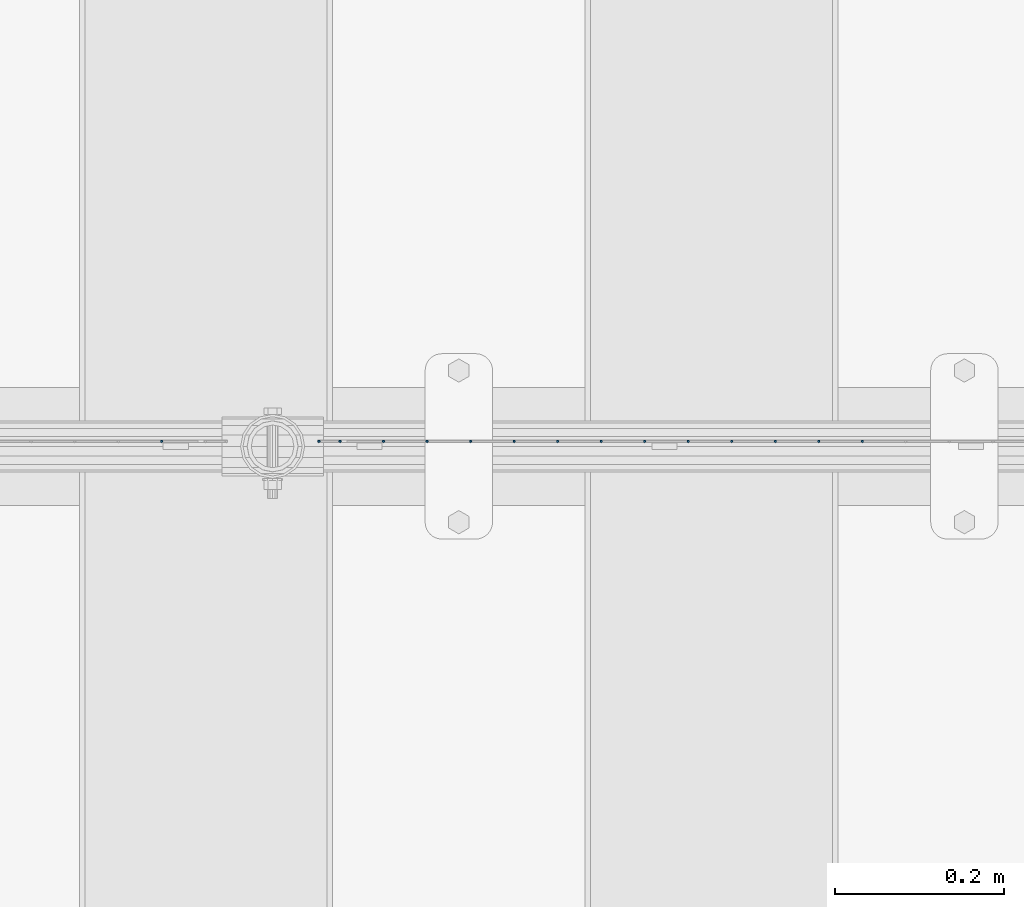
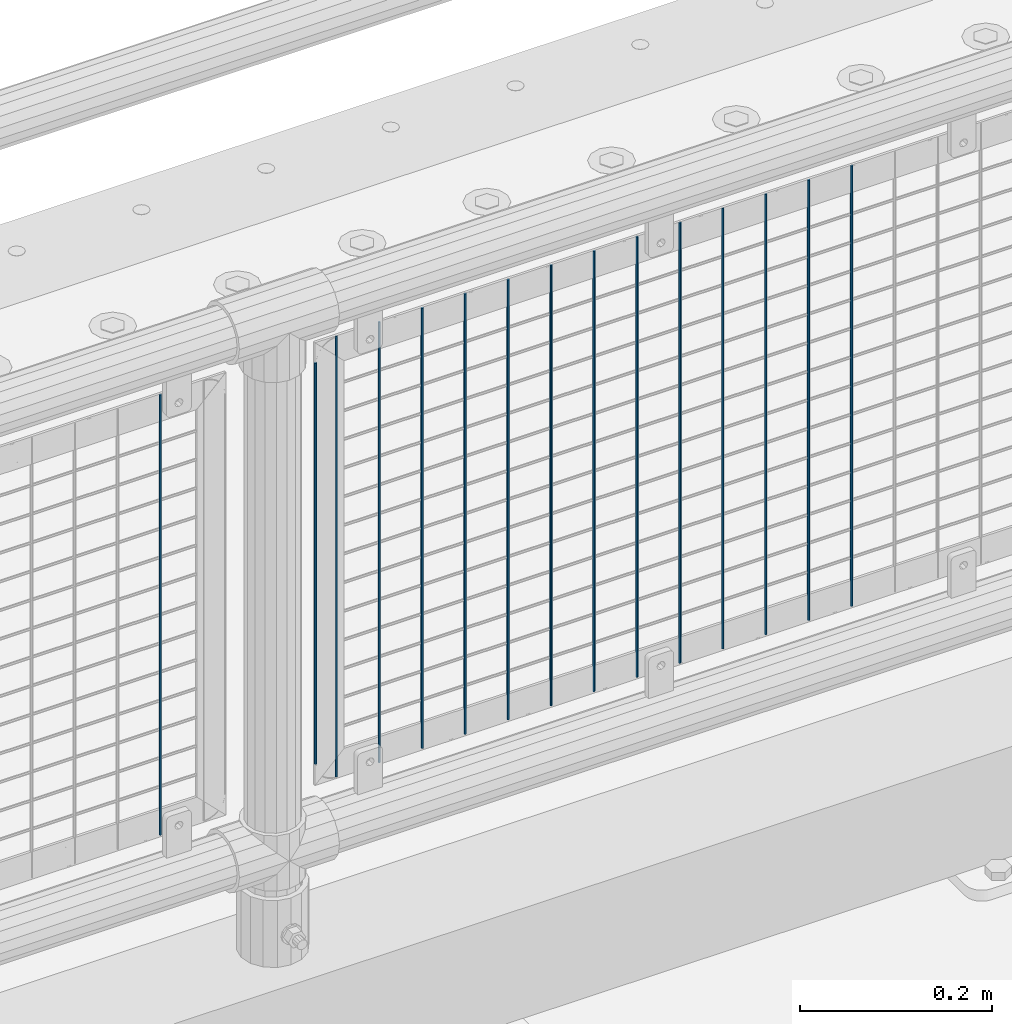
# One storey, part 56 of 193: 15 columns.
"""IFC2X3 building model written with IfcOpenShell, lengths in millimetres."""

from ifc_helpers import new_model, si_unit, frame, origin_with_axes, place, context, subcontext, project, spatial, faceted_brep, material, type_object, element, save


model = new_model("IFC2X3")

# Units and contexts
model_context = context("Model", 3, precision=1e-05, world=origin_with_axes())
body_context = subcontext(model_context, "Body", "Model", "MODEL_VIEW")
ifc_project = project(units=[si_unit("LENGTHUNIT", "METRE", prefix="MILLI"), si_unit("AREAUNIT", "SQUARE_METRE"), si_unit("VOLUMEUNIT", "CUBIC_METRE"), si_unit("MASSUNIT", "GRAM", prefix="KILO"), si_unit("TIMEUNIT", "SECOND"), si_unit("PLANEANGLEUNIT", "RADIAN"), si_unit("SOLIDANGLEUNIT", "STERADIAN"), si_unit("THERMODYNAMICTEMPERATUREUNIT", "DEGREE_CELSIUS"), si_unit("LUMINOUSINTENSITYUNIT", "LUMEN")], contexts=[model_context])

# Site, building, storey
site_placement = place(None, origin_with_axes())
site = spatial("IfcSite", under=ifc_project, at=site_placement, CompositionType="ELEMENT")
building_placement = place(site_placement, origin_with_axes())
building = spatial("IfcBuilding", under=site, at=building_placement, Name="Standard", CompositionType="ELEMENT")
storey_placement = place(building_placement, origin_with_axes())
storey = spatial("IfcBuildingStorey", under=building, at=storey_placement, Name="Undefined", CompositionType="ELEMENT", Elevation=0.0)

# Columns
ifc_material = material(Name="Misc_Undefined")
column_type = type_object("IfcColumnType", Name="D3", PredefinedType="NOTDEFINED")
for number, where, z_axis, x_axis in (
    (1, (-39471.14, 28670.5, 353.02), (-1.0, 0.0, 0.0), (0.0, 0.0, 1.0)),
    (2, (-39522.795, 28670.5, 353.02), (-1.0, 0.0, 0.0), (0.0, 0.0, 1.0)),
    (3, (-39574.45, 28670.5, 353.02), (-1.0, 0.0, 0.0), (0.0, 0.0, 1.0)),
    (4, (-39626.105, 28670.5, 353.02), (-1.0, 0.0, 0.0), (0.0, 0.0, 1.0)),
    (5, (-39677.76, 28670.5, 353.02), (-1.0, 0.0, 0.0), (0.0, 0.0, 1.0)),
    (6, (-39729.415, 28670.5, 353.02), (-1.0, 0.0, 0.0), (0.0, 0.0, 1.0)),
    (7, (-39781.07, 28670.5, 353.02), (-1.0, 0.0, 0.0), (0.0, 0.0, 1.0)),
    (8, (-39832.725, 28670.5, 353.02), (-1.0, 0.0, 0.0), (0.0, 0.0, 1.0)),
    (9, (-39884.38, 28670.5, 353.02), (-1.0, 0.0, 0.0), (0.0, 0.0, 1.0)),
    (10, (-39936.035, 28670.5, 353.02), (-1.0, 0.0, 0.0), (0.0, 0.0, 1.0)),
    (11, (-39987.69, 28670.5, 353.02), (-1.0, 0.0, 0.0), (0.0, 0.0, 1.0)),
    (12, (-40039.345, 28670.5, 353.02), (-1.0, 0.0, 0.0), (0.0, 0.0, 1.0)),
):
    element("IfcColumn", number, at=place(storey_placement, frame(where, z_axis=z_axis, x_axis=x_axis)), inside=storey, type_object=column_type, material=ifc_material, ObjectType="D3", context=body_context, shape_type="Brep", body=[
        faceted_brep([(0.0, -1.49999999999636, 3.63797880709171e-12), (0.0, -0.75, -1.29903810567669), (560.0, -0.75, -1.29903810567703), (560.0, -1.5, 0.0), (0.0, 0.75, -1.29903810567669), (560.0, 0.75, -1.29903810567703), (0.0, 1.50000000000364, 7.27595761418343e-12), (560.0, 1.5, 0.0), (0.0, 0.75, 1.29903810567669), (560.0, 0.75, 1.29903810567703), (0.0, -0.75, 1.29903810567669), (560.0, -0.75, 1.29903810567703)], [[[0, 1, 2, 3]], [[1, 4, 5, 2]], [[4, 6, 7, 5]], [[6, 8, 9, 7]], [[8, 10, 11, 9]], [[10, 0, 3, 11]], [[5, 7, 9, 11, 3, 2]], [[10, 8, 6, 4, 1, 0]]]),
    ])
column_placement = place(storey_placement, frame((-40116.0, 28670.5, 378.02), z_axis=(-1.0, 0.0, 0.0), x_axis=(0.0, 0.0, 1.0)))
element("IfcColumn", 13, at=column_placement, inside=storey, type_object=column_type, material=ifc_material, ObjectType="D3", context=body_context, shape_type="Brep", body=[
    faceted_brep([(0.0, -1.49999999999636, 3.63797880709171e-12), (0.0, -0.75, -1.29903810567669), (510.0, -0.75, -1.29903810567703), (510.0, -1.5, 0.0), (0.0, 0.75, -1.29903810567669), (510.0, 0.75, -1.29903810567703), (0.0, 1.50000000000364, 7.27595761418343e-12), (510.0, 1.5, 0.0), (0.0, 0.75, 1.29903810567669), (510.0, 0.75, 1.29903810567703), (0.0, -0.75, 1.29903810567669), (510.0, -0.75, 1.29903810567703)], [[[0, 1, 2, 3]], [[1, 4, 5, 2]], [[4, 6, 7, 5]], [[6, 8, 9, 7]], [[8, 10, 11, 9]], [[10, 0, 3, 11]], [[5, 7, 9, 11, 3, 2]], [[10, 8, 6, 4, 1, 0]]]),
])
for number, where, z_axis, x_axis in (
    (14, (-40091.0, 28670.5, 353.02), (-1.0, 0.0, 0.0), (0.0, 0.0, 1.0)),
    (15, (-40302.66, 28670.5, 353.02), (-1.0, 0.0, 0.0), (0.0, 0.0, 1.0)),
):
    element("IfcColumn", number, at=place(storey_placement, frame(where, z_axis=z_axis, x_axis=x_axis)), inside=storey, type_object=column_type, material=ifc_material, ObjectType="D3", context=body_context, shape_type="Brep", body=[
        faceted_brep([(0.0, -1.49999999999636, 3.63797880709171e-12), (0.0, -0.75, -1.29903810567669), (560.0, -0.75, -1.29903810567703), (560.0, -1.5, 0.0), (0.0, 0.75, -1.29903810567669), (560.0, 0.75, -1.29903810567703), (0.0, 1.50000000000364, 7.27595761418343e-12), (560.0, 1.5, 0.0), (0.0, 0.75, 1.29903810567669), (560.0, 0.75, 1.29903810567703), (0.0, -0.75, 1.29903810567669), (560.0, -0.75, 1.29903810567703)], [[[0, 1, 2, 3]], [[1, 4, 5, 2]], [[4, 6, 7, 5]], [[6, 8, 9, 7]], [[8, 10, 11, 9]], [[10, 0, 3, 11]], [[5, 7, 9, 11, 3, 2]], [[10, 8, 6, 4, 1, 0]]]),
    ])

save(model, "model.ifc")
